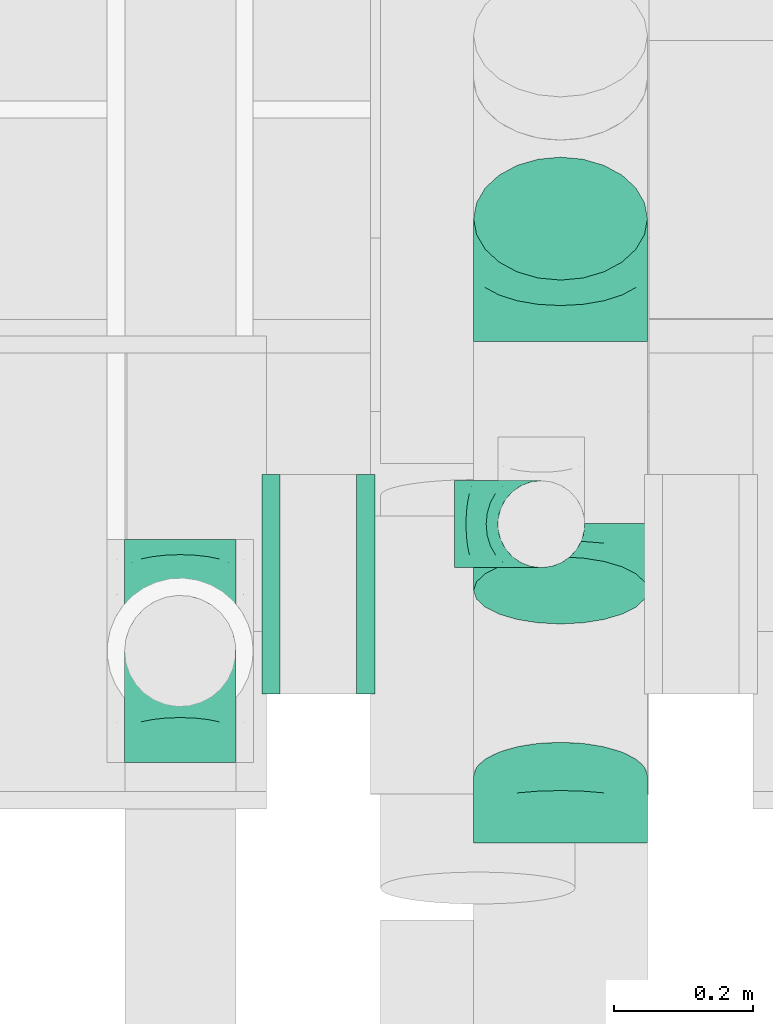
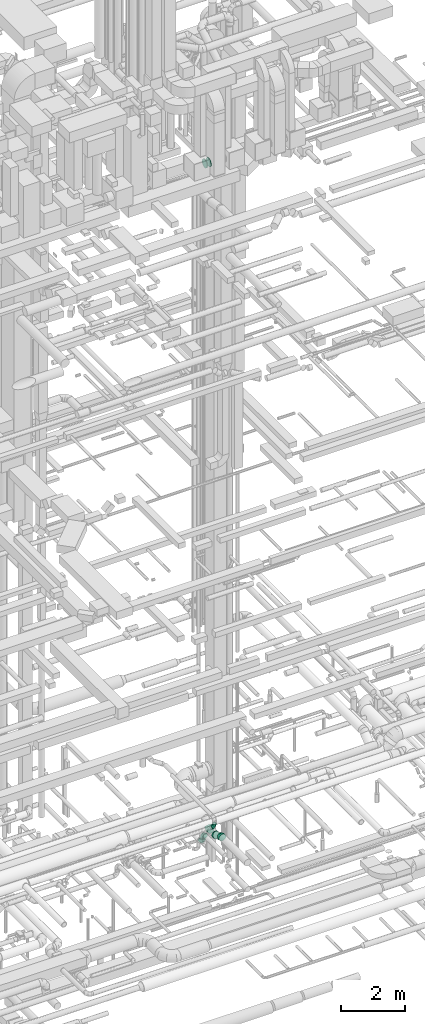
# One storey, part 222 of 337: 8 flow fittings.
"""IFC2X3 building model written with IfcOpenShell, lengths in millimetres."""

from ifc_helpers import new_model, entity, si_unit, converted_unit, derived_unit, direction, frame, origin, place, context, subcontext, project, spatial, faceted_brep, source, transform, mapped, material, type_object, type_shapes, element, save


model = new_model("IFC2X3")

# Units and contexts
model_context = context("Model", 3, precision=0.01, world=origin(), true_north=direction((6.12303176911189e-17, 1.0)))
body_context = subcontext(model_context, "Body", "Model", "MODEL_VIEW")
ifc_project = project(units=[si_unit("LENGTHUNIT", "METRE", prefix="MILLI"), si_unit("AREAUNIT", "SQUARE_METRE"), si_unit("VOLUMEUNIT", "CUBIC_METRE"), converted_unit("PLANEANGLEUNIT", "DEGREE", entity("IfcRatioMeasure", 0.0174532925199433), si_unit("PLANEANGLEUNIT", "RADIAN"), dimensions=[0, 0, 0, 0, 0, 0, 0]), si_unit("MASSUNIT", "GRAM", prefix="KILO"), derived_unit("MASSDENSITYUNIT", [(si_unit("MASSUNIT", "GRAM", prefix="KILO"), 1), (si_unit("LENGTHUNIT", "METRE"), -3)]), derived_unit("MOMENTOFINERTIAUNIT", [(si_unit("LENGTHUNIT", "METRE"), 4)]), si_unit("TIMEUNIT", "SECOND"), si_unit("FREQUENCYUNIT", "HERTZ"), si_unit("THERMODYNAMICTEMPERATUREUNIT", "DEGREE_CELSIUS"), derived_unit("THERMALTRANSMITTANCEUNIT", [(si_unit("MASSUNIT", "GRAM", prefix="KILO"), 1), (si_unit("THERMODYNAMICTEMPERATUREUNIT", "KELVIN"), -1), (si_unit("TIMEUNIT", "SECOND"), -3)]), derived_unit("VOLUMETRICFLOWRATEUNIT", [(si_unit("LENGTHUNIT", "METRE"), 3), (si_unit("TIMEUNIT", "SECOND"), -1)]), derived_unit("MASSFLOWRATEUNIT", [(si_unit("MASSUNIT", "GRAM", prefix="KILO"), 1), (si_unit("TIMEUNIT", "SECOND"), -1)]), derived_unit("ROTATIONALFREQUENCYUNIT", [(si_unit("TIMEUNIT", "SECOND"), -1)]), si_unit("ELECTRICCURRENTUNIT", "AMPERE"), si_unit("ELECTRICVOLTAGEUNIT", "VOLT"), si_unit("POWERUNIT", "WATT"), si_unit("FORCEUNIT", "NEWTON", prefix="KILO"), si_unit("ILLUMINANCEUNIT", "LUX"), si_unit("LUMINOUSFLUXUNIT", "LUMEN"), si_unit("LUMINOUSINTENSITYUNIT", "CANDELA"), derived_unit("USERDEFINED", [(si_unit("MASSUNIT", "GRAM", prefix="KILO"), -1), (si_unit("LENGTHUNIT", "METRE"), -2), (si_unit("TIMEUNIT", "SECOND"), 3), (si_unit("LUMINOUSFLUXUNIT", "LUMEN"), 1)]), derived_unit("LINEARVELOCITYUNIT", [(si_unit("LENGTHUNIT", "METRE"), 1), (si_unit("TIMEUNIT", "SECOND"), -1)]), si_unit("PRESSUREUNIT", "PASCAL"), derived_unit("USERDEFINED", [(si_unit("LENGTHUNIT", "METRE"), -2), (si_unit("MASSUNIT", "GRAM", prefix="KILO"), 1), (si_unit("TIMEUNIT", "SECOND"), -2)]), derived_unit("LINEARFORCEUNIT", [(si_unit("MASSUNIT", "GRAM", prefix="KILO"), 1), (si_unit("LENGTHUNIT", "METRE"), 1), (si_unit("TIMEUNIT", "SECOND"), -2), (si_unit("LENGTHUNIT", "METRE"), -1)]), derived_unit("PLANARFORCEUNIT", [(si_unit("MASSUNIT", "GRAM", prefix="KILO"), 1), (si_unit("LENGTHUNIT", "METRE"), 1), (si_unit("TIMEUNIT", "SECOND"), -2), (si_unit("LENGTHUNIT", "METRE"), -2)])], contexts=[model_context])

# Site, building, storey
site_placement = place(None, origin())
site = spatial("IfcSite", under=ifc_project, at=site_placement, CompositionType="ELEMENT")
building_placement = place(site_placement, origin())
building = spatial("IfcBuilding", under=site, at=building_placement, CompositionType="ELEMENT")
storey_placement = place(building_placement, origin())
storey = spatial("IfcBuildingStorey", under=building, at=storey_placement, CompositionType="ELEMENT", Elevation=0.0)

# Flow fittings
ifc_material = material()
duct_fitting_type_1 = type_object("IfcDuctFittingType", PredefinedType="NOTDEFINED", material=ifc_material)
shared_shape_1 = source(origin(), body_context, "Body", "Brep", [
    faceted_brep([(-160.0, 0.0, -80.0), (-160.0, -20.71, -77.27), (-160.0, -40.0, -69.28), (-160.0, -56.57, -56.57), (-160.0, -69.28, -40.0), (-160.0, -77.27, -20.71), (-160.0, -80.0, 0.0), (-160.0, -77.27, 20.71), (-160.0, -69.28, 40.0), (-160.0, -56.57, 56.57), (-160.0, -40.0, 69.28), (-160.0, -20.71, 77.27), (-160.0, 0.0, 80.0), (-160.0, 20.71, 77.27), (-160.0, 40.0, 69.28), (-160.0, 56.57, 56.57), (-160.0, 69.28, 40.0), (-160.0, 77.27, 20.71), (-160.0, 80.0, 0.0), (-160.0, 77.27, -20.71), (-160.0, 69.28, -40.0), (-160.0, 56.57, -56.57), (-160.0, 40.0, -69.28), (-160.0, 20.71, -77.27), (-122.68, 20.71, 77.27), (-127.85, 40.0, 69.28), (-117.13, 0.0, 80.0), (-132.29, 56.57, 56.57), (-137.83, 77.27, 20.71), (-138.56, 80.0, 0.0), (-135.69, 69.28, 40.0), (-135.69, 69.28, -40.0), (-132.29, 56.57, -56.57), (-137.83, 77.27, -20.71), (-122.68, 20.71, -77.27), (-117.13, 0.0, -80.0), (-127.85, 40.0, -69.28), (-111.58, -20.71, -77.27), (-106.41, -40.0, -69.28), (-101.97, -56.57, -56.57), (-98.56, -69.28, -40.0), (-96.42, -77.27, -20.71), (-95.69, -80.0, 0.0), (-96.42, -77.27, 20.71), (-98.56, -69.28, 40.0), (-101.97, -56.57, 56.57), (-106.41, -40.0, 69.28), (-111.58, -20.71, 77.27), (-58.03, 58.03, 77.27), (-72.15, 72.15, 69.28), (-42.87, 42.87, 80.0), (-84.28, 84.28, 56.57), (-93.59, 93.59, 40.0), (-99.44, 99.44, 20.71), (-101.44, 101.44, 0.0), (-99.44, 99.44, -20.71), (-93.59, 93.59, -40.0), (-84.28, 84.28, -56.57), (-58.03, 58.03, -77.27), (-42.87, 42.87, -80.0), (-72.15, 72.15, -69.28), (-27.71, 27.71, -77.27), (-13.59, 13.59, -69.28), (-1.46, 1.46, -56.57), (7.85, -7.85, -40.0), (13.7, -13.7, -20.71), (15.69, -15.69, 0.0), (13.7, -13.7, 20.71), (7.85, -7.85, 40.0), (-1.46, 1.46, 56.57), (-13.59, 13.59, 69.28), (-27.71, 27.71, 77.27), (-20.71, 122.68, 77.27), (-40.0, 127.85, 69.28), (0.0, 117.13, 80.0), (-56.57, 132.29, 56.57), (-69.28, 135.69, 40.0), (-77.27, 137.83, 20.71), (-80.0, 138.56, 0.0), (-77.27, 137.83, -20.71), (-69.28, 135.69, -40.0), (-56.57, 132.29, -56.57), (-20.71, 122.68, -77.27), (0.0, 117.13, -80.0), (-40.0, 127.85, -69.28), (20.71, 111.58, -77.27), (40.0, 106.41, -69.28), (56.57, 101.97, -56.57), (69.28, 98.56, -40.0), (77.27, 96.42, -20.71), (80.0, 95.69, 0.0), (77.27, 96.42, 20.71), (69.28, 98.56, 40.0), (56.57, 101.97, 56.57), (40.0, 106.41, 69.28), (20.71, 111.58, 77.27), (-20.71, 160.0, -77.27), (-40.0, 160.0, -69.28), (-56.57, 160.0, -56.57), (-69.28, 160.0, -40.0), (-77.27, 160.0, -20.71), (-80.0, 160.0, 0.0), (-77.27, 160.0, 20.71), (-69.28, 160.0, 40.0), (-56.57, 160.0, 56.57), (-40.0, 160.0, 69.28), (-20.71, 160.0, 77.27), (0.0, 160.0, 80.0), (20.71, 160.0, 77.27), (40.0, 160.0, 69.28), (56.57, 160.0, 56.57), (69.28, 160.0, 40.0), (77.27, 160.0, 20.71), (80.0, 160.0, 0.0), (77.27, 160.0, -20.71), (69.28, 160.0, -40.0), (56.57, 160.0, -56.57), (40.0, 160.0, -69.28), (20.71, 160.0, -77.27), (0.0, 160.0, -80.0)], [[[0, 1, 2, 3, 4, 5, 6, 7, 8, 9, 10, 11, 12, 13, 14, 15, 16, 17, 18, 19, 20, 21, 22, 23]], [[24, 25, 14, 13]], [[26, 24, 13, 12]], [[14, 25, 27, 15]], [[28, 29, 18, 17]], [[30, 28, 17, 16]], [[15, 27, 30, 16]], [[20, 31, 32, 21]], [[33, 31, 20, 19]], [[18, 29, 33, 19]], [[34, 35, 0, 23]], [[36, 34, 23, 22]], [[32, 36, 22, 21]], [[1, 0, 35, 37]], [[2, 1, 37, 38]], [[3, 2, 38, 39]], [[5, 4, 40, 41]], [[6, 5, 41, 42]], [[39, 40, 4, 3]], [[6, 42, 43, 7]], [[7, 43, 44, 8]], [[8, 44, 45, 9]], [[9, 45, 46, 10]], [[10, 46, 47, 11]], [[26, 12, 11, 47]], [[48, 49, 25, 24]], [[50, 48, 24, 26]], [[27, 25, 49, 51]], [[52, 53, 28, 30]], [[51, 52, 30, 27]], [[29, 28, 53, 54]], [[55, 56, 31, 33]], [[54, 55, 33, 29]], [[32, 31, 56, 57]], [[58, 59, 35, 34]], [[60, 58, 34, 36]], [[57, 60, 36, 32]], [[37, 35, 59, 61]], [[38, 37, 61, 62]], [[39, 38, 62, 63]], [[41, 40, 64, 65]], [[42, 41, 65, 66]], [[63, 64, 40, 39]], [[43, 42, 66, 67]], [[44, 43, 67, 68]], [[68, 69, 45, 44]], [[46, 45, 69, 70]], [[47, 46, 70, 71]], [[26, 47, 71, 50]], [[72, 73, 49, 48]], [[74, 72, 48, 50]], [[51, 49, 73, 75]], [[76, 77, 53, 52]], [[75, 76, 52, 51]], [[54, 53, 77, 78]], [[79, 80, 56, 55]], [[78, 79, 55, 54]], [[57, 56, 80, 81]], [[82, 83, 59, 58]], [[84, 82, 58, 60]], [[81, 84, 60, 57]], [[61, 59, 83, 85]], [[62, 61, 85, 86]], [[63, 62, 86, 87]], [[65, 64, 88, 89]], [[66, 65, 89, 90]], [[87, 88, 64, 63]], [[67, 66, 90, 91]], [[68, 67, 91, 92]], [[92, 93, 69, 68]], [[70, 69, 93, 94]], [[71, 70, 94, 95]], [[50, 71, 95, 74]], [[96, 97, 98, 99, 100, 101, 102, 103, 104, 105, 106, 107, 108, 109, 110, 111, 112, 113, 114, 115, 116, 117, 118, 119]], [[72, 74, 107, 106]], [[73, 72, 106, 105]], [[75, 73, 105, 104]], [[77, 76, 103, 102]], [[78, 77, 102, 101]], [[75, 104, 103, 76]], [[78, 101, 100, 79]], [[79, 100, 99, 80]], [[80, 99, 98, 81]], [[84, 97, 96, 82]], [[82, 96, 119, 83]], [[84, 81, 98, 97]], [[118, 117, 86, 85]], [[119, 118, 85, 83]], [[116, 87, 86, 117]], [[88, 115, 114, 89]], [[89, 114, 113, 90]], [[115, 88, 87, 116]], [[112, 111, 92, 91]], [[113, 112, 91, 90]], [[111, 110, 93, 92]], [[95, 94, 109, 108]], [[74, 95, 108, 107]], [[110, 109, 94, 93]]]),
])
type_shapes(duct_fitting_type_1, [shared_shape_1])
for number, where, z_axis, x_axis in (
    (1, (56623.29, 8160.18, 3100.0), (-1.0, 0.0, 0.0), (0.0, -1.0, 0.0)),
    (2, (56623.29, 8160.18, 3430.0), (1.0, -5.70028121315694e-08, 0.0), (0.0, 0.0, 1.0)),
):
    element("IfcFlowFitting", number, at=place(storey_placement, frame(where, z_axis=z_axis, x_axis=x_axis)), inside=storey, type_object=duct_fitting_type_1, material=ifc_material, context=body_context, shape_type="MappedRepresentation", body=[
        mapped(shared_shape_1, transform((0.0, 0.0, 0.0), scale=1.0)),
    ])
duct_fitting_type_2 = type_object("IfcDuctFittingType", PredefinedType="NOTDEFINED", material=ifc_material)
shared_shape_2 = source(origin(), body_context, "Body", "Brep", [
    faceted_brep([(-125.0, 0.0, -62.5), (-125.0, -16.18, -60.37), (-125.0, -31.25, -54.13), (-125.0, -44.19, -44.19), (-125.0, -54.13, -31.25), (-125.0, -60.37, -16.18), (-125.0, -62.5, 0.0), (-125.0, -60.37, 16.18), (-125.0, -54.13, 31.25), (-125.0, -44.19, 44.19), (-125.0, -31.25, 54.13), (-125.0, -16.18, 60.37), (-125.0, 0.0, 62.5), (-125.0, 16.18, 60.37), (-125.0, 31.25, 54.13), (-125.0, 44.19, 44.19), (-125.0, 54.13, 31.25), (-125.0, 60.37, 16.18), (-125.0, 62.5, 0.0), (-125.0, 60.37, -16.18), (-125.0, 54.13, -31.25), (-125.0, 44.19, -44.19), (-125.0, 31.25, -54.13), (-125.0, 16.18, -60.37), (-95.84, 16.18, 60.37), (-99.88, 31.25, 54.13), (-91.51, 0.0, 62.5), (-103.35, 44.19, 44.19), (-107.68, 60.37, 16.18), (-108.25, 62.5, 0.0), (-106.01, 54.13, 31.25), (-106.01, 54.13, -31.25), (-103.35, 44.19, -44.19), (-107.68, 60.37, -16.18), (-95.84, 16.18, -60.37), (-91.51, 0.0, -62.5), (-99.88, 31.25, -54.13), (-87.17, -16.18, -60.37), (-83.13, -31.25, -54.13), (-79.66, -44.19, -44.19), (-77.0, -54.13, -31.25), (-75.33, -60.37, -16.18), (-74.76, -62.5, 0.0), (-75.33, -60.37, 16.18), (-77.0, -54.13, 31.25), (-79.66, -44.19, 44.19), (-83.13, -31.25, 54.13), (-87.17, -16.18, 60.37), (-45.34, 45.34, 60.37), (-56.37, 56.37, 54.13), (-33.49, 33.49, 62.5), (-65.85, 65.85, 44.19), (-73.12, 73.12, 31.25), (-77.69, 77.69, 16.18), (-79.25, 79.25, 0.0), (-77.69, 77.69, -16.18), (-73.12, 73.12, -31.25), (-65.85, 65.85, -44.19), (-45.34, 45.34, -60.37), (-33.49, 33.49, -62.5), (-56.37, 56.37, -54.13), (-21.65, 21.65, -60.37), (-10.62, 10.62, -54.13), (-1.14, 1.14, -44.19), (6.13, -6.13, -31.25), (10.7, -10.7, -16.18), (12.26, -12.26, 0.0), (10.7, -10.7, 16.18), (6.13, -6.13, 31.25), (-1.14, 1.14, 44.19), (-10.62, 10.62, 54.13), (-21.65, 21.65, 60.37), (-16.18, 95.84, 60.37), (-31.25, 99.88, 54.13), (0.0, 91.51, 62.5), (-44.19, 103.35, 44.19), (-54.13, 106.01, 31.25), (-60.37, 107.68, 16.18), (-62.5, 108.25, 0.0), (-60.37, 107.68, -16.18), (-54.13, 106.01, -31.25), (-44.19, 103.35, -44.19), (-16.18, 95.84, -60.37), (0.0, 91.51, -62.5), (-31.25, 99.88, -54.13), (16.18, 87.17, -60.37), (31.25, 83.13, -54.13), (44.19, 79.66, -44.19), (54.13, 77.0, -31.25), (60.37, 75.33, -16.18), (62.5, 74.76, 0.0), (60.37, 75.33, 16.18), (54.13, 77.0, 31.25), (44.19, 79.66, 44.19), (31.25, 83.13, 54.13), (16.18, 87.17, 60.37), (-16.18, 125.0, -60.37), (-31.25, 125.0, -54.13), (-44.19, 125.0, -44.19), (-54.13, 125.0, -31.25), (-60.37, 125.0, -16.18), (-62.5, 125.0, 0.0), (-60.37, 125.0, 16.18), (-54.13, 125.0, 31.25), (-44.19, 125.0, 44.19), (-31.25, 125.0, 54.13), (-16.18, 125.0, 60.37), (0.0, 125.0, 62.5), (16.18, 125.0, 60.37), (31.25, 125.0, 54.13), (44.19, 125.0, 44.19), (54.13, 125.0, 31.25), (60.37, 125.0, 16.18), (62.5, 125.0, 0.0), (60.37, 125.0, -16.18), (54.13, 125.0, -31.25), (44.19, 125.0, -44.19), (31.25, 125.0, -54.13), (16.18, 125.0, -60.37), (0.0, 125.0, -62.5)], [[[0, 1, 2, 3, 4, 5, 6, 7, 8, 9, 10, 11, 12, 13, 14, 15, 16, 17, 18, 19, 20, 21, 22, 23]], [[24, 25, 14, 13]], [[26, 24, 13, 12]], [[14, 25, 27, 15]], [[28, 29, 18, 17]], [[30, 28, 17, 16]], [[15, 27, 30, 16]], [[20, 31, 32, 21]], [[33, 31, 20, 19]], [[18, 29, 33, 19]], [[34, 35, 0, 23]], [[36, 34, 23, 22]], [[21, 32, 36, 22]], [[1, 0, 35, 37]], [[2, 1, 37, 38]], [[38, 39, 3, 2]], [[5, 4, 40, 41]], [[6, 5, 41, 42]], [[39, 40, 4, 3]], [[6, 42, 43, 7]], [[7, 43, 44, 8]], [[45, 9, 8, 44]], [[9, 45, 46, 10]], [[10, 46, 47, 11]], [[26, 12, 11, 47]], [[48, 49, 25, 24]], [[50, 48, 24, 26]], [[27, 25, 49, 51]], [[52, 53, 28, 30]], [[51, 52, 30, 27]], [[29, 28, 53, 54]], [[55, 56, 31, 33]], [[54, 55, 33, 29]], [[57, 32, 31, 56]], [[58, 59, 35, 34]], [[60, 58, 34, 36]], [[57, 60, 36, 32]], [[37, 35, 59, 61]], [[38, 37, 61, 62]], [[39, 38, 62, 63]], [[41, 40, 64, 65]], [[42, 41, 65, 66]], [[63, 64, 40, 39]], [[43, 42, 66, 67]], [[44, 43, 67, 68]], [[68, 69, 45, 44]], [[46, 45, 69, 70]], [[47, 46, 70, 71]], [[26, 47, 71, 50]], [[72, 73, 49, 48]], [[74, 72, 48, 50]], [[51, 49, 73, 75]], [[76, 77, 53, 52]], [[75, 76, 52, 51]], [[54, 53, 77, 78]], [[79, 80, 56, 55]], [[78, 79, 55, 54]], [[81, 57, 56, 80]], [[82, 83, 59, 58]], [[84, 82, 58, 60]], [[81, 84, 60, 57]], [[61, 59, 83, 85]], [[62, 61, 85, 86]], [[63, 62, 86, 87]], [[65, 64, 88, 89]], [[66, 65, 89, 90]], [[87, 88, 64, 63]], [[67, 66, 90, 91]], [[68, 67, 91, 92]], [[92, 93, 69, 68]], [[70, 69, 93, 94]], [[71, 70, 94, 95]], [[50, 71, 95, 74]], [[96, 97, 98, 99, 100, 101, 102, 103, 104, 105, 106, 107, 108, 109, 110, 111, 112, 113, 114, 115, 116, 117, 118, 119]], [[72, 74, 107, 106]], [[73, 72, 106, 105]], [[75, 73, 105, 104]], [[77, 76, 103, 102]], [[78, 77, 102, 101]], [[75, 104, 103, 76]], [[78, 101, 100, 79]], [[79, 100, 99, 80]], [[80, 99, 98, 81]], [[96, 119, 83, 82]], [[97, 96, 82, 84]], [[84, 81, 98, 97]], [[83, 119, 118, 85]], [[85, 118, 117, 86]], [[116, 87, 86, 117]], [[88, 115, 114, 89]], [[89, 114, 113, 90]], [[115, 88, 87, 116]], [[91, 90, 113, 112]], [[92, 91, 112, 111]], [[111, 110, 93, 92]], [[95, 94, 109, 108]], [[74, 95, 108, 107]], [[110, 109, 94, 93]]]),
])
type_shapes(duct_fitting_type_2, [shared_shape_2])
flow_fitting_1_placement = place(storey_placement, frame((57142.4, 8342.51, 3400.0), z_axis=(0.0, 1.0, 0.0), x_axis=(0.0, 0.0, -1.0)))
element("IfcFlowFitting", 3, at=flow_fitting_1_placement, inside=storey, type_object=duct_fitting_type_2, material=ifc_material, context=body_context, shape_type="MappedRepresentation", body=[
    mapped(shared_shape_2, transform((0.0, 0.0, 0.0), scale=1.0)),
])
duct_fitting_type_3 = type_object("IfcDuctFittingType", PredefinedType="NOTDEFINED", material=ifc_material)
shared_shape_3 = source(origin(), body_context, "Body", "Brep", [
    faceted_brep([(-103.55, 0.0, -125.0), (-103.55, -32.35, -120.74), (-103.55, -62.5, -108.25), (-103.55, -88.39, -88.39), (-103.55, -108.25, -62.5), (-103.55, -120.74, -32.35), (-103.55, -125.0, 0.0), (-103.55, -120.74, 32.35), (-103.55, -108.25, 62.5), (-103.55, -88.39, 88.39), (-103.55, -62.5, 108.25), (-103.55, -32.35, 120.74), (-103.55, 0.0, 125.0), (-103.55, 32.35, 120.74), (-103.55, 62.5, 108.25), (-103.55, 88.39, 88.39), (-103.55, 108.25, 62.5), (-103.55, 120.74, 32.35), (-103.55, 125.0, 0.0), (-103.55, 120.74, -32.35), (-103.55, 108.25, -62.5), (-103.55, 88.39, -88.39), (-103.55, 62.5, -108.25), (-103.55, 32.35, -120.74), (-13.4, 32.35, 120.74), (-25.89, 62.5, 108.25), (0.0, 0.0, 125.0), (-36.61, 88.39, 88.39), (-44.84, 108.25, 62.5), (-50.01, 120.74, 32.35), (-51.78, 125.0, 0.0), (-50.01, 120.74, -32.35), (-44.84, 108.25, -62.5), (-36.61, 88.39, -88.39), (-13.4, 32.35, -120.74), (0.0, 0.0, -125.0), (-25.89, 62.5, -108.25), (13.4, -32.35, -120.74), (25.89, -62.5, -108.25), (36.61, -88.39, -88.39), (44.84, -108.25, -62.5), (50.01, -120.74, -32.35), (51.78, -125.0, 0.0), (50.01, -120.74, 32.35), (44.84, -108.25, 62.5), (36.61, -88.39, 88.39), (25.89, -62.5, 108.25), (13.4, -32.35, 120.74), (73.22, 73.22, 125.0), (50.35, 96.1, 120.74), (29.03, 117.42, 108.25), (10.72, 135.72, 88.39), (-3.32, 149.77, 62.5), (-12.15, 158.6, 32.35), (-15.17, 161.61, 0.0), (-12.15, 158.6, -32.35), (-3.32, 149.77, -62.5), (10.72, 135.72, -88.39), (29.03, 117.42, -108.25), (50.35, 96.1, -120.74), (73.22, 73.22, -125.0), (96.1, 50.35, -120.74), (117.42, 29.03, -108.25), (135.72, 10.72, -88.39), (149.77, -3.32, -62.5), (158.6, -12.15, -32.35), (161.61, -15.17, 0.0), (158.6, -12.15, 32.35), (149.77, -3.32, 62.5), (135.72, 10.72, 88.39), (117.42, 29.03, 108.25), (96.1, 50.35, 120.74)], [[[0, 1, 2, 3, 4, 5, 6, 7, 8, 9, 10, 11, 12, 13, 14, 15, 16, 17, 18, 19, 20, 21, 22, 23]], [[24, 25, 14, 13]], [[26, 24, 13, 12]], [[14, 25, 27, 15]], [[28, 29, 17, 16]], [[28, 16, 15, 27]], [[30, 18, 17, 29]], [[31, 32, 20, 19]], [[30, 31, 19, 18]], [[32, 33, 21, 20]], [[34, 35, 0, 23]], [[36, 34, 23, 22]], [[33, 36, 22, 21]], [[1, 0, 35, 37]], [[2, 1, 37, 38]], [[38, 39, 3, 2]], [[5, 4, 40, 41]], [[6, 5, 41, 42]], [[39, 40, 4, 3]], [[6, 42, 43, 7]], [[7, 43, 44, 8]], [[8, 44, 45, 9]], [[9, 45, 46, 10]], [[10, 46, 47, 11]], [[26, 12, 11, 47]], [[24, 26, 48, 49]], [[25, 24, 49, 50]], [[27, 25, 50, 51]], [[29, 28, 52, 53]], [[30, 29, 53, 54]], [[51, 52, 28, 27]], [[30, 54, 55, 31]], [[31, 55, 56, 32]], [[57, 33, 32, 56]], [[36, 58, 59, 34]], [[34, 59, 60, 35]], [[58, 36, 33, 57]], [[35, 60, 61, 37]], [[37, 61, 62, 38]], [[63, 39, 38, 62]], [[40, 64, 65, 41]], [[41, 65, 66, 42]], [[64, 40, 39, 63]], [[43, 42, 66, 67]], [[44, 43, 67, 68]], [[68, 69, 45, 44]], [[47, 46, 70, 71]], [[26, 47, 71, 48]], [[69, 70, 46, 45]], [[59, 58, 57, 56, 55, 54, 53, 52, 51, 50, 49, 48, 71, 70, 69, 68, 67, 66, 65, 64, 63, 62, 61, 60]]]),
])
type_shapes(duct_fitting_type_3, [shared_shape_3])
flow_fitting_2_placement = place(storey_placement, frame((57170.09, 8708.62, 3100.0), z_axis=(1.0, 0.0, 0.0), x_axis=(0.0, 1.0, 0.0)))
element("IfcFlowFitting", 4, at=flow_fitting_2_placement, inside=storey, type_object=duct_fitting_type_3, material=ifc_material, context=body_context, shape_type="MappedRepresentation", body=[
    mapped(shared_shape_3, transform((0.0, 0.0, 0.0), scale=1.0)),
])
duct_fitting_type_4 = type_object("IfcDuctFittingType", PredefinedType="NOTDEFINED", material=ifc_material)
shared_shape_4 = source(origin(), body_context, "Body", "Brep", [
    faceted_brep([(20.0, 40.76, -152.13), (20.0, 78.75, -136.4), (20.0, 111.37, -111.37), (20.0, 136.4, -78.75), (20.0, 152.13, -40.76), (20.0, 157.5, 0.0), (20.0, 152.13, 40.76), (20.0, 136.4, 78.75), (20.0, 111.37, 111.37), (20.0, 78.75, 136.4), (20.0, 40.76, 152.13), (20.0, 0.0, 157.5), (20.0, -40.76, 152.13), (20.0, -78.75, 136.4), (20.0, -111.37, 111.37), (20.0, -136.4, 78.75), (20.0, -152.13, 40.76), (20.0, -157.5, 0.0), (20.0, -152.13, -40.76), (20.0, -136.4, -78.75), (20.0, -111.37, -111.37), (20.0, -78.75, -136.4), (20.0, -40.76, -152.13), (20.0, 0.0, -157.5), (0.0, 0.0, 157.5), (0.0, 40.76, 152.13), (-6.1, 40.76, 152.13), (-6.1, 0.0, 157.5), (0.0, 78.75, 136.4), (-6.1, 78.75, 136.4), (0.0, 111.37, 111.37), (-6.1, 111.37, 111.37), (0.0, 136.4, 78.75), (0.0, 152.13, 40.76), (-6.1, 152.13, 40.76), (-6.1, 136.4, 78.75), (0.0, 157.5, 0.0), (-6.1, 157.5, 0.0), (0.0, 152.13, -40.76), (-6.1, 152.13, -40.76), (0.0, 136.4, -78.75), (-6.1, 136.4, -78.75), (0.0, 111.37, -111.37), (-6.1, 111.37, -111.37), (0.0, 0.0, -157.5), (-6.1, 0.0, -157.5), (-6.1, 40.76, -152.13), (0.0, 40.76, -152.13), (-6.1, 78.75, -136.4), (0.0, 78.75, -136.4), (0.0, -40.76, -152.13), (-6.1, -40.76, -152.13), (0.0, -78.75, -136.4), (-6.1, -78.75, -136.4), (0.0, -111.37, -111.37), (-6.1, -111.37, -111.37), (0.0, -136.4, -78.75), (0.0, -152.13, -40.76), (-6.1, -152.13, -40.76), (-6.1, -136.4, -78.75), (0.0, -157.5, 0.0), (-6.1, -157.5, 0.0), (0.0, -152.13, 40.76), (-6.1, -152.13, 40.76), (0.0, -136.4, 78.75), (-6.1, -136.4, 78.75), (0.0, -111.37, 111.37), (-6.1, -111.37, 111.37), (0.0, -78.75, 136.4), (0.0, -40.76, 152.13), (-6.1, -40.76, 152.13), (-6.1, -78.75, 136.4)], [[[0, 1, 2, 3, 4, 5, 6, 7, 8, 9, 10, 11, 12, 13, 14, 15, 16, 17, 18, 19, 20, 21, 22, 23]], [[24, 11, 10, 25, 26, 27]], [[25, 10, 9, 28, 29, 26]], [[28, 9, 8, 30, 31, 29]], [[32, 7, 6, 33, 34, 35]], [[33, 6, 5, 36, 37, 34]], [[30, 8, 7, 32, 35, 31]], [[36, 5, 4, 38, 39, 37]], [[38, 4, 3, 40, 41, 39]], [[40, 3, 2, 42, 43, 41]], [[0, 23, 44, 45, 46, 47]], [[1, 0, 47, 46, 48, 49]], [[49, 48, 43, 42, 2, 1]], [[44, 23, 22, 50, 51, 45]], [[50, 22, 21, 52, 53, 51]], [[52, 21, 20, 54, 55, 53]], [[56, 19, 18, 57, 58, 59]], [[57, 18, 17, 60, 61, 58]], [[54, 20, 19, 56, 59, 55]], [[60, 17, 16, 62, 63, 61]], [[62, 16, 15, 64, 65, 63]], [[64, 15, 14, 66, 67, 65]], [[68, 13, 12, 69, 70, 71]], [[69, 12, 11, 24, 27, 70]], [[66, 14, 13, 68, 71, 67]], [[45, 51, 53, 55, 59, 58, 61, 63, 65, 67, 71, 70, 27, 26, 29, 31, 35, 34, 37, 39, 41, 43, 48, 46]]]),
])
type_shapes(duct_fitting_type_4, [shared_shape_4])
flow_fitting_3_placement = place(storey_placement, frame((56897.0, 8256.2, 28795.0), z_axis=(0.0, 1.0, 0.0), x_axis=(-1.0, 0.0, 0.0)))
element("IfcFlowFitting", 5, at=flow_fitting_3_placement, inside=storey, type_object=duct_fitting_type_4, material=ifc_material, context=body_context, shape_type="MappedRepresentation", body=[
    mapped(shared_shape_4, transform((0.0, 0.0, 0.0), scale=1.0)),
])
duct_fitting_type_5 = type_object("IfcDuctFittingType", PredefinedType="NOTDEFINED", material=ifc_material)
shared_shape_5 = source(origin(), body_context, "Body", "Brep", [
    faceted_brep([(20.0, 0.0, -157.5), (20.0, 40.76, -152.13), (20.0, 78.75, -136.4), (20.0, 111.37, -111.37), (20.0, 136.4, -78.75), (20.0, 152.13, -40.76), (20.0, 157.5, 0.0), (20.0, 152.13, 40.76), (20.0, 136.4, 78.75), (20.0, 111.37, 111.37), (20.0, 78.75, 136.4), (20.0, 40.76, 152.13), (20.0, 0.0, 157.5), (20.0, -40.76, 152.13), (20.0, -78.75, 136.4), (20.0, -111.37, 111.37), (20.0, -136.4, 78.75), (20.0, -152.13, 40.76), (20.0, -157.5, 0.0), (20.0, -152.13, -40.76), (20.0, -136.4, -78.75), (20.0, -111.37, -111.37), (20.0, -78.75, -136.4), (20.0, -40.76, -152.13), (0.0, 0.0, 157.5), (-6.1, 0.0, 157.5), (-6.1, -40.76, 152.13), (0.0, -40.76, 152.13), (-6.1, -78.75, 136.4), (0.0, -78.75, 136.4), (0.0, -111.37, 111.37), (-6.1, -111.37, 111.37), (0.0, -136.4, 78.75), (-6.1, -136.4, 78.75), (-6.1, -152.13, 40.76), (0.0, -152.13, 40.76), (-6.1, -157.5, 0.0), (0.0, -157.5, 0.0), (-6.1, -152.13, -40.76), (0.0, -152.13, -40.76), (-6.1, -136.4, -78.75), (0.0, -136.4, -78.75), (0.0, -111.37, -111.37), (-6.1, -111.37, -111.37), (0.0, 0.0, -157.5), (0.0, -40.76, -152.13), (-6.1, -40.76, -152.13), (-6.1, 0.0, -157.5), (0.0, -78.75, -136.4), (-6.1, -78.75, -136.4), (-6.1, 40.76, -152.13), (0.0, 40.76, -152.13), (-6.1, 78.75, -136.4), (0.0, 78.75, -136.4), (0.0, 111.37, -111.37), (-6.1, 111.37, -111.37), (0.0, 136.4, -78.75), (-6.1, 136.4, -78.75), (-6.1, 152.13, -40.76), (0.0, 152.13, -40.76), (-6.1, 157.5, 0.0), (0.0, 157.5, 0.0), (-6.1, 152.13, 40.76), (0.0, 152.13, 40.76), (-6.1, 136.4, 78.75), (0.0, 136.4, 78.75), (0.0, 111.37, 111.37), (-6.1, 111.37, 111.37), (0.0, 78.75, 136.4), (-6.1, 78.75, 136.4), (-6.1, 40.76, 152.13), (0.0, 40.76, 152.13)], [[[0, 1, 2, 3, 4, 5, 6, 7, 8, 9, 10, 11, 12, 13, 14, 15, 16, 17, 18, 19, 20, 21, 22, 23]], [[13, 12, 24, 25, 26, 27]], [[14, 13, 27, 26, 28, 29]], [[30, 15, 14, 29, 28, 31]], [[17, 16, 32, 33, 34, 35]], [[18, 17, 35, 34, 36, 37]], [[32, 16, 15, 30, 31, 33]], [[19, 18, 37, 36, 38, 39]], [[20, 19, 39, 38, 40, 41]], [[42, 21, 20, 41, 40, 43]], [[44, 0, 23, 45, 46, 47]], [[48, 49, 46, 45, 23, 22]], [[22, 21, 42, 43, 49, 48]], [[1, 0, 44, 47, 50, 51]], [[2, 1, 51, 50, 52, 53]], [[54, 3, 2, 53, 52, 55]], [[5, 4, 56, 57, 58, 59]], [[6, 5, 59, 58, 60, 61]], [[56, 4, 3, 54, 55, 57]], [[7, 6, 61, 60, 62, 63]], [[8, 7, 63, 62, 64, 65]], [[66, 9, 8, 65, 64, 67]], [[11, 10, 68, 69, 70, 71]], [[12, 11, 71, 70, 25, 24]], [[68, 10, 9, 66, 67, 69]], [[46, 49, 43, 40, 38, 36, 34, 33, 31, 28, 26, 25, 70, 69, 67, 64, 62, 60, 58, 57, 55, 52, 50, 47]]]),
])
type_shapes(duct_fitting_type_5, [shared_shape_5])
flow_fitting_4_placement = place(storey_placement, frame((56747.0, 8256.2, 28795.0), z_axis=(0.0, 0.0, -1.0), x_axis=(1.0, 0.0, 0.0)))
element("IfcFlowFitting", 6, at=flow_fitting_4_placement, inside=storey, type_object=duct_fitting_type_5, material=ifc_material, context=body_context, shape_type="MappedRepresentation", body=[
    mapped(shared_shape_5, transform((0.0, 0.0, 0.0), scale=1.0)),
])
duct_fitting_type_6 = type_object("IfcDuctFittingType", PredefinedType="NOTDEFINED", material=ifc_material)
shared_shape_6 = source(origin(), body_context, "Body", "Brep", [
    faceted_brep([(-50.13, 0.0, -125.0), (-50.13, -32.35, -120.74), (-50.13, -62.5, -108.25), (-50.13, -88.39, -88.39), (-50.13, -108.25, -62.5), (-50.13, -120.74, -32.35), (-50.13, -125.0, 0.0), (-50.13, -120.74, 32.35), (-50.13, -108.25, 62.5), (-50.13, -88.39, 88.39), (-50.13, -62.5, 108.25), (-50.13, -32.35, 120.74), (-50.13, 0.0, 125.0), (-50.13, 32.35, 120.74), (-50.13, 62.5, 108.25), (-50.13, 88.39, 88.39), (-50.13, 108.25, 62.5), (-50.13, 120.74, 32.35), (-50.13, 125.0, 0.0), (-50.13, 120.74, -32.35), (-50.13, 108.25, -62.5), (-50.13, 88.39, -88.39), (-50.13, 62.5, -108.25), (-50.13, 32.35, -120.74), (-6.49, 32.35, 120.74), (-12.53, 62.5, 108.25), (0.0, 0.0, 125.0), (-17.72, 88.39, 88.39), (-24.21, 120.74, 32.35), (-25.06, 125.0, 0.0), (-21.71, 108.25, 62.5), (-21.71, 108.25, -62.5), (-17.72, 88.39, -88.39), (-24.21, 120.74, -32.35), (-6.49, 32.35, -120.74), (0.0, 0.0, -125.0), (-12.53, 62.5, -108.25), (6.49, -32.35, -120.74), (12.53, -62.5, -108.25), (17.72, -88.39, -88.39), (21.71, -108.25, -62.5), (24.21, -120.74, -32.35), (25.06, -125.0, 0.0), (24.21, -120.74, 32.35), (21.71, -108.25, 62.5), (17.72, -88.39, 88.39), (12.53, -62.5, 108.25), (6.49, -32.35, 120.74), (46.25, 19.32, 125.0), (33.78, 49.18, 120.74), (22.16, 76.99, 108.25), (12.18, 100.88, 88.39), (4.52, 119.21, 62.5), (-0.3, 130.73, 32.35), (-1.94, 134.66, 0.0), (-0.3, 130.73, -32.35), (4.52, 119.21, -62.5), (12.18, 100.88, -88.39), (22.16, 76.99, -108.25), (33.78, 49.18, -120.74), (46.25, 19.32, -125.0), (58.72, -10.53, -120.74), (70.35, -38.34, -108.25), (80.33, -62.23, -88.39), (87.98, -80.56, -62.5), (92.8, -92.08, -32.35), (94.44, -96.01, 0.0), (92.8, -92.08, 32.35), (87.98, -80.56, 62.5), (80.33, -62.23, 88.39), (70.35, -38.34, 108.25), (58.72, -10.53, 120.74)], [[[0, 1, 2, 3, 4, 5, 6, 7, 8, 9, 10, 11, 12, 13, 14, 15, 16, 17, 18, 19, 20, 21, 22, 23]], [[24, 25, 14, 13]], [[26, 24, 13, 12]], [[14, 25, 27, 15]], [[28, 29, 18, 17]], [[30, 28, 17, 16]], [[15, 27, 30, 16]], [[20, 31, 32, 21]], [[33, 31, 20, 19]], [[18, 29, 33, 19]], [[34, 35, 0, 23]], [[36, 34, 23, 22]], [[32, 36, 22, 21]], [[1, 0, 35, 37]], [[2, 1, 37, 38]], [[3, 2, 38, 39]], [[5, 4, 40, 41]], [[6, 5, 41, 42]], [[39, 40, 4, 3]], [[6, 42, 43, 7]], [[7, 43, 44, 8]], [[45, 9, 8, 44]], [[9, 45, 46, 10]], [[10, 46, 47, 11]], [[26, 12, 11, 47]], [[24, 26, 48, 49]], [[25, 24, 49, 50]], [[27, 25, 50, 51]], [[28, 30, 52, 53]], [[29, 28, 53, 54]], [[27, 51, 52, 30]], [[29, 54, 55, 33]], [[33, 55, 56, 31]], [[31, 56, 57, 32]], [[36, 58, 59, 34]], [[34, 59, 60, 35]], [[36, 32, 57, 58]], [[35, 60, 61, 37]], [[37, 61, 62, 38]], [[63, 39, 38, 62]], [[40, 64, 65, 41]], [[41, 65, 66, 42]], [[64, 40, 39, 63]], [[67, 68, 44, 43]], [[66, 67, 43, 42]], [[68, 69, 45, 44]], [[47, 46, 70, 71]], [[26, 47, 71, 48]], [[69, 70, 46, 45]], [[59, 58, 57, 56, 55, 54, 53, 52, 51, 50, 49, 48, 71, 70, 69, 68, 67, 66, 65, 64, 63, 62, 61, 60]]]),
])
type_shapes(duct_fitting_type_6, [shared_shape_6])
for number, where, z_axis, x_axis in (
    (7, (57170.09, 7934.47, 3250.0), (-1.0, 0.0, 0.0), (0.0, 1.0, 0.0)),
    (8, (57170.09, 8293.49, 3100.0), (-1.0, 0.0, 0.0), (0.0, -1.0, 0.0)),
):
    element("IfcFlowFitting", number, at=place(storey_placement, frame(where, z_axis=z_axis, x_axis=x_axis)), inside=storey, type_object=duct_fitting_type_6, material=ifc_material, context=body_context, shape_type="MappedRepresentation", body=[
        mapped(shared_shape_6, transform((0.0, 0.0, 0.0), scale=1.0)),
    ])

save(model, "model.ifc")
